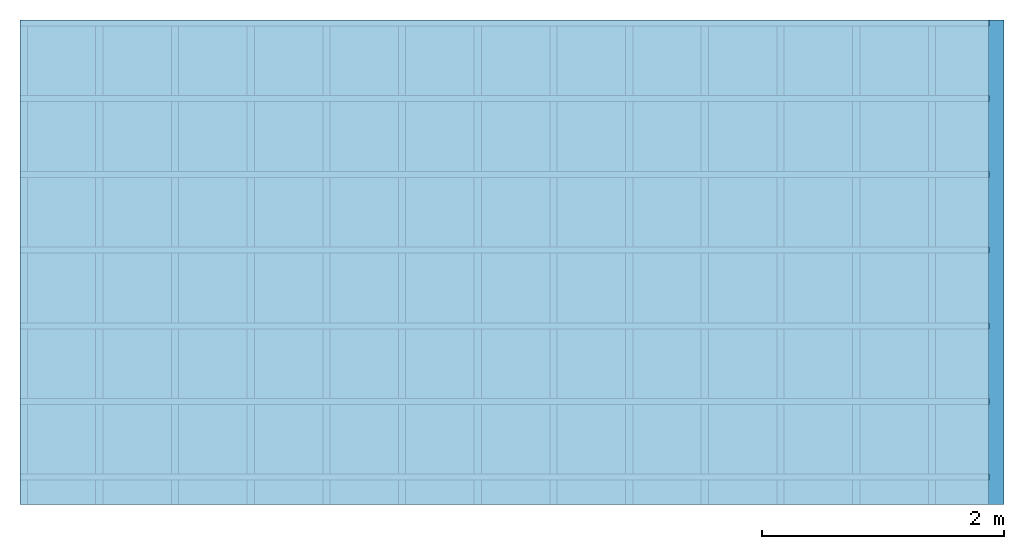
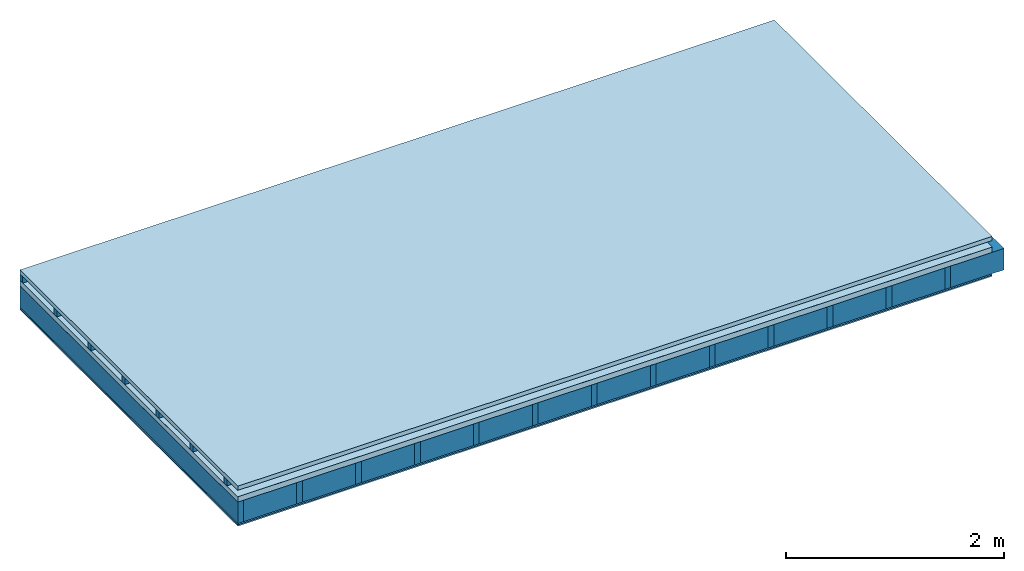
# One storey: 5 plates, 3 members, 1 element without a shape of its own.
"""IFC4 building model written with IfcOpenShell, lengths in metres."""

from ifc_helpers import new_model, si_unit, derived_unit, direction, frame, frame_2d, origin, origin_with_axes, place, context, project, spatial, rectangle, extrude, material, layer, layer_set, type_object, element, aggregate, save


model = new_model("IFC4")

# Units and contexts
plan_context = context("Plan", 3, precision=1e-05, world=origin(), true_north=direction((0.0, 1.0)))
model_context = context("Model", 3, precision=1e-05, world=origin(), true_north=direction((0.0, 1.0)))
ifc_project = project(units=[si_unit("LENGTHUNIT", "METRE"), derived_unit("SOUNDPRESSUREUNIT", [(si_unit("PRESSUREUNIT", "PASCAL", prefix="MICRO"), 0)]), si_unit("ENERGYUNIT", "JOULE", prefix="MEGA"), si_unit("MASSUNIT", "GRAM", prefix="KILO"), derived_unit("THERMALTRANSMITTANCEUNIT", [(si_unit("POWERUNIT", "WATT"), 1), (si_unit("AREAUNIT", "SQUARE_METRE"), -1), (si_unit("THERMODYNAMICTEMPERATUREUNIT", "KELVIN"), -1)]), derived_unit("AREADENSITYUNIT", [(si_unit("MASSUNIT", "GRAM", prefix="KILO"), 1), (si_unit("AREAUNIT", "SQUARE_METRE"), -1)]), derived_unit("USERDEFINED", [(si_unit("ENERGYUNIT", "JOULE", prefix="MEGA"), 1), (si_unit("AREAUNIT", "SQUARE_METRE"), -1)])], contexts=[plan_context, model_context])

# Site, building, storey
site = spatial("IfcSite", under=ifc_project)
building_placement = place(None, origin())
building = spatial("IfcBuilding", under=site, at=building_placement)
storey_placement = place(building_placement, origin())
storey = spatial("IfcBuildingStorey", under=building, at=storey_placement)

# Slab, members, plates
ifc_material_1 = material(Name="Roof tiles", Category="03.015")
ifc_layer_1 = layer(ifc_material_1, 0.047, Name="Roofing")
ifc_layer_2 = layer(None, 0.072, Name="Battens / profiles")
ifc_material_2 = material(Name="Roofing underlay", Category="09.008")
ifc_layer_3 = layer(ifc_material_2, 0.00018, Name="Under the roof")
ifc_material_3 = material(Category="10.009")
ifc_layer_4 = layer(ifc_material_3, 0.06, Name="Exterior insulation layer 1")
ifc_material_4 = material(Name="no composite action")
ifc_layer_5 = layer(ifc_material_4, 0.0, Name="Bond")
ifc_layer_6 = layer(None, 0.24, Name="Supporting structure")
ifc_material_5 = material(Name="of the art")
ifc_layer_7 = layer(ifc_material_5, 0.0, Name="Bond")
ifc_material_6 = material(Name="OSB panel", Category="07.013")
ifc_layer_8 = layer(ifc_material_6, 0.015, Name="Lower layer 1")
ifc_material_7 = material(Name="Plasterboard type A", Category="03.008")
ifc_layer_9 = layer(ifc_material_7, 0.015, Name="Lower 2nd layer")
ifc_material_8 = material(Name="Glued joints")
ifc_layer_10 = layer(ifc_material_8, 0.0, Name="Surface below")
ifc_layer_set = layer_set([ifc_layer_1, ifc_layer_2, ifc_layer_3, ifc_layer_4, ifc_layer_5, ifc_layer_6, ifc_layer_7, ifc_layer_8, ifc_layer_9, ifc_layer_10])
slab_type = type_object("IfcSlabType", Name="E0110", PredefinedType="NOTDEFINED", material=ifc_layer_set)
slab_placement = place(None, frame((0.0, 0.0, 0.0), z_axis=(0.0, 0.0, -1.0), x_axis=(1.0, 0.0, 0.0)))
slab = element("IfcSlab", 1, at=slab_placement, inside=storey, type_object=slab_type, material=ifc_layer_set, Name="Slab #1")
ifc_material_9 = material()
member_1_placement = place(slab_placement, origin())
member_1 = element("IfcMember", 2, at=member_1_placement, material=ifc_material_9, Name="Battens / profiles", context=plan_context, shape_type="SweptSolid", body=[
    extrude(rectangle(XDim=0.05, YDim=0.072, at=frame_2d((0.025, 0.036), x_axis=(1.0, 0.0))), frame((0.0, 0.0, 0.047), z_axis=(1.0, 0.0, 0.0), x_axis=(0.0, 1.0, 0.0)), (0.0, 0.0, 1.0), 8.0),
    extrude(rectangle(XDim=0.05, YDim=0.072, at=frame_2d((0.025, 0.036), x_axis=(1.0, 0.0))), frame((0.0, 0.625, 0.047), z_axis=(1.0, 0.0, 0.0), x_axis=(0.0, 1.0, 0.0)), (0.0, 0.0, 1.0), 8.0),
    extrude(rectangle(XDim=0.05, YDim=0.072, at=frame_2d((0.025, 0.036), x_axis=(1.0, 0.0))), frame((0.0, 1.25, 0.047), z_axis=(1.0, 0.0, 0.0), x_axis=(0.0, 1.0, 0.0)), (0.0, 0.0, 1.0), 8.0),
    extrude(rectangle(XDim=0.05, YDim=0.072, at=frame_2d((0.025, 0.036), x_axis=(1.0, 0.0))), frame((0.0, 1.875, 0.047), z_axis=(1.0, 0.0, 0.0), x_axis=(0.0, 1.0, 0.0)), (0.0, 0.0, 1.0), 8.0),
    extrude(rectangle(XDim=0.05, YDim=0.072, at=frame_2d((0.025, 0.036), x_axis=(1.0, 0.0))), frame((0.0, 2.5, 0.047), z_axis=(1.0, 0.0, 0.0), x_axis=(0.0, 1.0, 0.0)), (0.0, 0.0, 1.0), 8.0),
    extrude(rectangle(XDim=0.05, YDim=0.072, at=frame_2d((0.025, 0.036), x_axis=(1.0, 0.0))), frame((0.0, 3.125, 0.047), z_axis=(1.0, 0.0, 0.0), x_axis=(0.0, 1.0, 0.0)), (0.0, 0.0, 1.0), 8.0),
    extrude(rectangle(XDim=0.05, YDim=0.072, at=frame_2d((0.025, 0.036), x_axis=(1.0, 0.0))), frame((0.0, 3.75, 0.047), z_axis=(1.0, 0.0, 0.0), x_axis=(0.0, 1.0, 0.0)), (0.0, 0.0, 1.0), 8.0),
])
ifc_material_10 = material()
member_2_placement = place(slab_placement, origin())
member_2 = element("IfcMember", 3, at=member_2_placement, material=ifc_material_10, Name="Supporting structure", context=plan_context, shape_type="SweptSolid", body=[
    extrude(rectangle(XDim=0.06, YDim=0.24, at=frame_2d((0.03, 0.12), x_axis=(1.0, 0.0))), frame((0.0, 4.0, 0.17918), z_axis=(0.0, -1.0, 0.0), x_axis=(1.0, 0.0, 0.0)), (0.0, 0.0, 1.0), 4.0),
    extrude(rectangle(XDim=0.06, YDim=0.24, at=frame_2d((0.03, 0.12), x_axis=(1.0, 0.0))), frame((0.625, 4.0, 0.17918), z_axis=(0.0, -1.0, 0.0), x_axis=(1.0, 0.0, 0.0)), (0.0, 0.0, 1.0), 4.0),
    extrude(rectangle(XDim=0.06, YDim=0.24, at=frame_2d((0.03, 0.12), x_axis=(1.0, 0.0))), frame((1.25, 4.0, 0.17918), z_axis=(0.0, -1.0, 0.0), x_axis=(1.0, 0.0, 0.0)), (0.0, 0.0, 1.0), 4.0),
    extrude(rectangle(XDim=0.06, YDim=0.24, at=frame_2d((0.03, 0.12), x_axis=(1.0, 0.0))), frame((1.875, 4.0, 0.17918), z_axis=(0.0, -1.0, 0.0), x_axis=(1.0, 0.0, 0.0)), (0.0, 0.0, 1.0), 4.0),
    extrude(rectangle(XDim=0.06, YDim=0.24, at=frame_2d((0.03, 0.12), x_axis=(1.0, 0.0))), frame((2.5, 4.0, 0.17918), z_axis=(0.0, -1.0, 0.0), x_axis=(1.0, 0.0, 0.0)), (0.0, 0.0, 1.0), 4.0),
    extrude(rectangle(XDim=0.06, YDim=0.24, at=frame_2d((0.03, 0.12), x_axis=(1.0, 0.0))), frame((3.125, 4.0, 0.17918), z_axis=(0.0, -1.0, 0.0), x_axis=(1.0, 0.0, 0.0)), (0.0, 0.0, 1.0), 4.0),
    extrude(rectangle(XDim=0.06, YDim=0.24, at=frame_2d((0.03, 0.12), x_axis=(1.0, 0.0))), frame((3.75, 4.0, 0.17918), z_axis=(0.0, -1.0, 0.0), x_axis=(1.0, 0.0, 0.0)), (0.0, 0.0, 1.0), 4.0),
    extrude(rectangle(XDim=0.06, YDim=0.24, at=frame_2d((0.03, 0.12), x_axis=(1.0, 0.0))), frame((4.375, 4.0, 0.17918), z_axis=(0.0, -1.0, 0.0), x_axis=(1.0, 0.0, 0.0)), (0.0, 0.0, 1.0), 4.0),
    extrude(rectangle(XDim=0.06, YDim=0.24, at=frame_2d((0.03, 0.12), x_axis=(1.0, 0.0))), frame((5.0, 4.0, 0.17918), z_axis=(0.0, -1.0, 0.0), x_axis=(1.0, 0.0, 0.0)), (0.0, 0.0, 1.0), 4.0),
    extrude(rectangle(XDim=0.06, YDim=0.24, at=frame_2d((0.03, 0.12), x_axis=(1.0, 0.0))), frame((5.625, 4.0, 0.17918), z_axis=(0.0, -1.0, 0.0), x_axis=(1.0, 0.0, 0.0)), (0.0, 0.0, 1.0), 4.0),
    extrude(rectangle(XDim=0.06, YDim=0.24, at=frame_2d((0.03, 0.12), x_axis=(1.0, 0.0))), frame((6.25, 4.0, 0.17918), z_axis=(0.0, -1.0, 0.0), x_axis=(1.0, 0.0, 0.0)), (0.0, 0.0, 1.0), 4.0),
    extrude(rectangle(XDim=0.06, YDim=0.24, at=frame_2d((0.03, 0.12), x_axis=(1.0, 0.0))), frame((6.875, 4.0, 0.17918), z_axis=(0.0, -1.0, 0.0), x_axis=(1.0, 0.0, 0.0)), (0.0, 0.0, 1.0), 4.0),
    extrude(rectangle(XDim=0.06, YDim=0.24, at=frame_2d((0.03, 0.12), x_axis=(1.0, 0.0))), frame((7.5, 4.0, 0.17918), z_axis=(0.0, -1.0, 0.0), x_axis=(1.0, 0.0, 0.0)), (0.0, 0.0, 1.0), 4.0),
])
ifc_material_11 = material()
member_3_placement = place(slab_placement, origin())
member_3 = element("IfcMember", 4, at=member_3_placement, material=ifc_material_11, Name="Cavity", context=plan_context, shape_type="SweptSolid", body=[
    extrude(rectangle(XDim=0.565, YDim=0.24, at=frame_2d((0.2825, 0.12), x_axis=(1.0, 0.0))), frame((0.06, 4.0, 0.17918), z_axis=(0.0, -1.0, 0.0), x_axis=(1.0, 0.0, 0.0)), (0.0, 0.0, 1.0), 4.0),
    extrude(rectangle(XDim=0.565, YDim=0.24, at=frame_2d((0.2825, 0.12), x_axis=(1.0, 0.0))), frame((0.685, 4.0, 0.17918), z_axis=(0.0, -1.0, 0.0), x_axis=(1.0, 0.0, 0.0)), (0.0, 0.0, 1.0), 4.0),
    extrude(rectangle(XDim=0.565, YDim=0.24, at=frame_2d((0.2825, 0.12), x_axis=(1.0, 0.0))), frame((1.31, 4.0, 0.17918), z_axis=(0.0, -1.0, 0.0), x_axis=(1.0, 0.0, 0.0)), (0.0, 0.0, 1.0), 4.0),
    extrude(rectangle(XDim=0.565, YDim=0.24, at=frame_2d((0.2825, 0.12), x_axis=(1.0, 0.0))), frame((1.935, 4.0, 0.17918), z_axis=(0.0, -1.0, 0.0), x_axis=(1.0, 0.0, 0.0)), (0.0, 0.0, 1.0), 4.0),
    extrude(rectangle(XDim=0.565, YDim=0.24, at=frame_2d((0.2825, 0.12), x_axis=(1.0, 0.0))), frame((2.56, 4.0, 0.17918), z_axis=(0.0, -1.0, 0.0), x_axis=(1.0, 0.0, 0.0)), (0.0, 0.0, 1.0), 4.0),
    extrude(rectangle(XDim=0.565, YDim=0.24, at=frame_2d((0.2825, 0.12), x_axis=(1.0, 0.0))), frame((3.185, 4.0, 0.17918), z_axis=(0.0, -1.0, 0.0), x_axis=(1.0, 0.0, 0.0)), (0.0, 0.0, 1.0), 4.0),
    extrude(rectangle(XDim=0.565, YDim=0.24, at=frame_2d((0.2825, 0.12), x_axis=(1.0, 0.0))), frame((3.81, 4.0, 0.17918), z_axis=(0.0, -1.0, 0.0), x_axis=(1.0, 0.0, 0.0)), (0.0, 0.0, 1.0), 4.0),
    extrude(rectangle(XDim=0.565, YDim=0.24, at=frame_2d((0.2825, 0.12), x_axis=(1.0, 0.0))), frame((4.435, 4.0, 0.17918), z_axis=(0.0, -1.0, 0.0), x_axis=(1.0, 0.0, 0.0)), (0.0, 0.0, 1.0), 4.0),
    extrude(rectangle(XDim=0.565, YDim=0.24, at=frame_2d((0.2825, 0.12), x_axis=(1.0, 0.0))), frame((5.06, 4.0, 0.17918), z_axis=(0.0, -1.0, 0.0), x_axis=(1.0, 0.0, 0.0)), (0.0, 0.0, 1.0), 4.0),
    extrude(rectangle(XDim=0.565, YDim=0.24, at=frame_2d((0.2825, 0.12), x_axis=(1.0, 0.0))), frame((5.685, 4.0, 0.17918), z_axis=(0.0, -1.0, 0.0), x_axis=(1.0, 0.0, 0.0)), (0.0, 0.0, 1.0), 4.0),
    extrude(rectangle(XDim=0.565, YDim=0.24, at=frame_2d((0.2825, 0.12), x_axis=(1.0, 0.0))), frame((6.31, 4.0, 0.17918), z_axis=(0.0, -1.0, 0.0), x_axis=(1.0, 0.0, 0.0)), (0.0, 0.0, 1.0), 4.0),
    extrude(rectangle(XDim=0.565, YDim=0.24, at=frame_2d((0.2825, 0.12), x_axis=(1.0, 0.0))), frame((6.935, 4.0, 0.17918), z_axis=(0.0, -1.0, 0.0), x_axis=(1.0, 0.0, 0.0)), (0.0, 0.0, 1.0), 4.0),
    extrude(rectangle(XDim=0.565, YDim=0.24, at=frame_2d((0.2825, 0.12), x_axis=(1.0, 0.0))), frame((7.56, 4.0, 0.17918), z_axis=(0.0, -1.0, 0.0), x_axis=(1.0, 0.0, 0.0)), (0.0, 0.0, 1.0), 4.0),
])
plate_1_placement = place(slab_placement, origin())
plate_1 = element("IfcPlate", 5, at=plate_1_placement, material=ifc_material_1, Name="Roofing", context=plan_context, shape_type="SweptSolid", body=[
    extrude(rectangle(XDim=8.0, YDim=4.0, at=frame_2d((4.0, 2.0), x_axis=(1.0, 0.0))), origin_with_axes(), (0.0, 0.0, 1.0), 0.047),
])
plate_2_placement = place(slab_placement, origin())
plate_2 = element("IfcPlate", 6, at=plate_2_placement, material=ifc_material_2, Name="Under the roof", context=plan_context, shape_type="SweptSolid", body=[
    extrude(rectangle(XDim=8.0, YDim=4.0, at=frame_2d((4.0, 2.0), x_axis=(1.0, 0.0))), frame((0.0, 0.0, 0.119), z_axis=(0.0, 0.0, 1.0), x_axis=(1.0, 0.0, 0.0)), (0.0, 0.0, 1.0), 0.00018),
])
plate_3_placement = place(slab_placement, origin())
plate_3 = element("IfcPlate", 7, at=plate_3_placement, material=ifc_material_3, Name="Exterior insulation layer 1", context=plan_context, shape_type="SweptSolid", body=[
    extrude(rectangle(XDim=8.0, YDim=4.0, at=frame_2d((4.0, 2.0), x_axis=(1.0, 0.0))), frame((0.0, 0.0, 0.11918), z_axis=(0.0, 0.0, 1.0), x_axis=(1.0, 0.0, 0.0)), (0.0, 0.0, 1.0), 0.06),
])
plate_4_placement = place(slab_placement, origin())
plate_4 = element("IfcPlate", 8, at=plate_4_placement, material=ifc_material_6, Name="Lower layer 1", context=plan_context, shape_type="SweptSolid", body=[
    extrude(rectangle(XDim=8.0, YDim=4.0, at=frame_2d((4.0, 2.0), x_axis=(1.0, 0.0))), frame((0.0, 0.0, 0.41918), z_axis=(0.0, 0.0, 1.0), x_axis=(1.0, 0.0, 0.0)), (0.0, 0.0, 1.0), 0.015),
])
plate_5_placement = place(slab_placement, origin())
plate_5 = element("IfcPlate", 9, at=plate_5_placement, material=ifc_material_7, Name="Lower 2nd layer", context=plan_context, shape_type="SweptSolid", body=[
    extrude(rectangle(XDim=8.0, YDim=4.0, at=frame_2d((4.0, 2.0), x_axis=(1.0, 0.0))), frame((0.0, 0.0, 0.43418), z_axis=(0.0, 0.0, 1.0), x_axis=(1.0, 0.0, 0.0)), (0.0, 0.0, 1.0), 0.015),
])
aggregate(slab, [plate_1, member_1, plate_2, plate_3, member_2, member_3, plate_4, plate_5])

save(model, "model.ifc")
